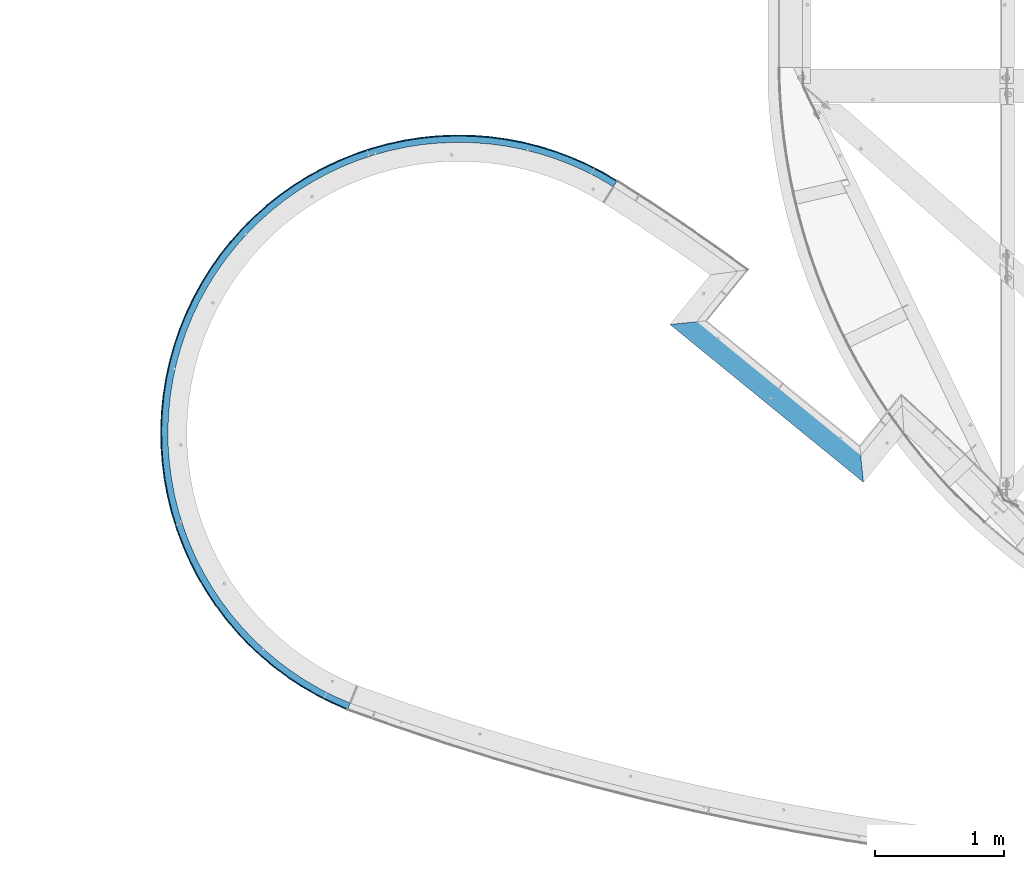
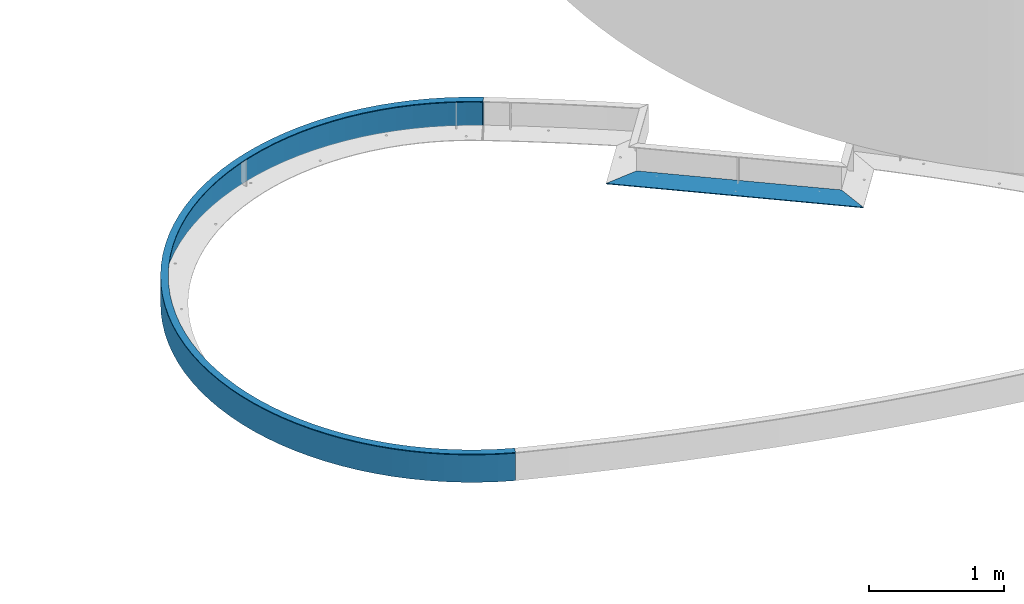
# One storey, part 1139 of 1763: 3 beams, 2 elements without a shape of their own.
"""IFC2X3 building model written with IfcOpenShell, lengths in millimetres."""

from ifc_helpers import new_model, si_unit, frame, origin_with_axes, place, context, subcontext, project, spatial, faceted_brep, material, type_object, element, aggregate, save


model = new_model("IFC2X3")

# Units and contexts
model_context = context("Model", 3, precision=1e-05, world=origin_with_axes())
body_context = subcontext(model_context, "Body", "Model", "MODEL_VIEW")
ifc_project = project(units=[si_unit("LENGTHUNIT", "METRE", prefix="MILLI"), si_unit("AREAUNIT", "SQUARE_METRE"), si_unit("VOLUMEUNIT", "CUBIC_METRE"), si_unit("MASSUNIT", "GRAM", prefix="KILO"), si_unit("TIMEUNIT", "SECOND"), si_unit("PLANEANGLEUNIT", "RADIAN"), si_unit("SOLIDANGLEUNIT", "STERADIAN"), si_unit("THERMODYNAMICTEMPERATUREUNIT", "DEGREE_CELSIUS"), si_unit("LUMINOUSINTENSITYUNIT", "LUMEN")], contexts=[model_context])

# Site, building, storey
site_placement = place(None, origin_with_axes())
site = spatial("IfcSite", under=ifc_project, at=site_placement, CompositionType="ELEMENT")
building_placement = place(site_placement, origin_with_axes())
building = spatial("IfcBuilding", under=site, at=building_placement, Name="Undefined", CompositionType="ELEMENT")
storey_placement = place(building_placement, origin_with_axes())
storey = spatial("IfcBuildingStorey", under=building, at=storey_placement, Name="Undefined", CompositionType="ELEMENT", Elevation=0.0)

# Assembly, beam
assembly_1_placement = place(storey_placement, origin_with_axes())
assembly_1 = element("IfcElementAssembly", 1, at=assembly_1_placement, inside=storey, Name="PLATE", AssemblyPlace="NOTDEFINED", PredefinedType="RIGID_FRAME")
ifc_material = material(Name="STEEL/A36")
beam_type_1 = type_object("IfcBeamType", PredefinedType="NOTDEFINED")
beam_1_placement = place(assembly_1_placement, frame((-50551.7806836382, 61435.7488480634, -250.825), z_axis=(0.632146851379196, 0.774848603464812, 0.0), x_axis=(0.774848603464803, -0.632146851379207, 0.0)))
beam_1 = element("IfcBeam", 2, at=beam_1_placement, type_object=beam_type_1, material=ifc_material, Name="PLATE", context=body_context, shape_type="Brep", body=[
    faceted_brep([(1733.19834197282, 3.17500000000001, 98.4249999978765), (1733.19834197282, -3.17500000000001, 98.4249999978765), (1930.03816630962, -3.17500000000001, -98.4250000016746), (1930.03816630962, 3.17500000000001, -98.4250000016746), (196.860502942538, -3.17500000000001, 98.4249999994627), (3.14685166813433e-10, -3.17500000000001, -98.4249999999156), (5.59484760742635e-08, 3.17500000000001, -98.4250000019238), (196.860502942538, 3.17500000000001, 98.4249999994627)], [[[0, 1, 2, 3]], [[2, 1, 4, 5]], [[3, 2, 5, 6]], [[0, 3, 6, 7]], [[1, 0, 7, 4]], [[6, 5, 4, 7]]]),
])
aggregate(assembly_1, [beam_1])

# Assembly, beams
assembly_2_placement = place(storey_placement, origin_with_axes())
assembly_2 = element("IfcElementAssembly", 3, at=assembly_2_placement, inside=storey, Name="PLATE", AssemblyPlace="NOTDEFINED", PredefinedType="RIGID_FRAME")
beam_type_2 = type_object("IfcBeamType", PredefinedType="NOTDEFINED")
beam_2_placement = place(assembly_2_placement, frame((-53103.23759363, 58381.757357184, -130.175), z_axis=(0.0, 0.0, 1.0), x_axis=(-0.350524826944054, 0.93655343985052, 0.0)))
beam_2 = element("IfcBeam", 4, at=beam_2_placement, type_object=beam_type_2, material=ifc_material, Name="PLATE", context=body_context, shape_type="Brep", body=[
    faceted_brep([(9.08736150742334, 3.46457929573444, 123.825), (2.34236171624798, 1.03151245606205, 123.825), (2.34236171624798, 1.03151245606205, -123.825), (9.10397851659218, 3.44847585066236, -123.825), (-9.89530235528946e-10, 3.17499999998108, -123.825), (-9.89530235528946e-10, 3.17499999998108, 123.825), (91.7775950844662, 97.8795264448527, 123.825), (91.7775950844662, 97.8795264448527, -123.825), (188.821100887682, 187.180323025095, 123.825), (188.821100887682, 187.180323025095, -123.825), (290.812861357786, 270.785078180852, 123.825), (290.812861357786, 270.785078180852, -123.825), (397.419023139155, 348.420125412711, 123.825), (397.419023139155, 348.420125412711, -123.825), (508.290628387724, 419.831339084303, 123.825), (508.290628387724, 419.831339084303, -123.825), (623.064757027547, 484.784966261039, 123.825), (623.064757027547, 484.784966261039, -123.825), (741.365714710279, 543.068391862096, 123.825), (741.365714710279, 543.068391862096, -123.825), (862.806262589191, 594.490834621192, 123.825), (862.806262589191, 594.490834621192, -123.825), (986.988884882318, 638.883971577801, 123.825), (986.988884882318, 638.883971577801, -123.825), (1113.50709007529, 676.102489054894, 123.825), (1113.50709007529, 676.102489054894, -123.825), (1241.94674150496, 706.024558319503, 123.825), (1241.94674150496, 706.024558319503, -123.825), (1371.88741296792, 728.552234369148, 123.825), (1371.88741296792, 728.552234369148, -123.825), (1502.90376491715, 743.611776538808, 123.825), (1502.90376491715, 743.611776538808, -123.825), (1634.56693674136, 751.153889878933, 123.825), (1634.56693674136, 751.153889878933, -123.825), (1766.44595057011, 751.153886514374, 123.825), (1766.44595057011, 751.153886514374, -123.825), (1898.10912200947, 743.611766456161, 123.825), (1898.10912200947, 743.611766456161, -123.825), (2029.1254731903, 728.552217601402, 123.825), (2029.1254731903, 728.552217601395, -123.825), (2159.06614350379, 706.024534921544, 123.825), (2159.06614350379, 706.024534921544, -123.825), (2287.50579340667, 676.10245910332, 123.825), (2287.50579340667, 676.10245910332, -123.825), (2414.02399670058, 638.883935170645, 123.825), (2414.02399670058, 638.883935170645, -123.825), (2538.20661672855, 594.490791877633, 123.825), (2538.20661672855, 594.490791877633, -123.825), (2659.64716198364, 543.068342922052, 123.825), (2659.64716198364, 543.068342922052, -123.825), (2777.94811669247, 484.784911284696, 123.825), (2777.94811669247, 484.784911284696, -123.825), (2892.72224201803, 419.83127825163, 123.825), (2892.72224201803, 419.83127825163, -123.825), (3003.59384362286, 348.420058922824, 123.825), (3003.59384362286, 348.420058922824, -123.825), (3110.20000144291, 270.785006251401, 123.825), (3110.20000144291, 270.785006251401, -123.825), (3212.19175764707, 187.18024589153, 123.825), (3212.19175764707, 187.180245891526, -123.825), (3309.23525889374, 97.8794443596453, 123.825), (3309.23525889374, 97.8794443596453, -123.825), (3401.01284914491, 3.17491323186914, 123.825), (3401.01284914484, 3.1749132320474, -123.825), (3487.22410946216, -96.6233476819216, 123.825), (3487.22410946216, -96.6233476819216, -123.825), (3567.58684137736, -201.188665096819, 123.825), (3567.58684137736, -201.188665096819, -123.825), (3641.83799062415, -310.178761539035, 123.825), (3641.83799062415, -310.178761539035, -123.825), (3709.73450820304, -423.236875744129, 123.825), (3709.73450820304, -423.236875744129, -123.825), (3771.05414596258, -539.992930456479, 123.825), (3771.05414596258, -539.992930456479, -123.825), (3825.59618409225, -660.064743816703, 123.825), (3825.59618409225, -660.064743816703, -123.825), (3873.18208814609, -783.059280371515, 123.825), (3873.18208814609, -783.059280371515, -123.825), (3913.65609344582, -908.573937611007, 123.825), (3913.65609344582, -908.573937611007, -123.825), (3946.88571495132, -1036.19786382219, 123.825), (3946.88571495132, -1036.19786382219, -123.825), (3972.76218092848, -1165.51330294484, 123.825), (3972.76218092848, -1165.51330294484, -123.825), (3991.20078899585, -1296.09696202779, 123.825), (3991.20078899585, -1296.09696202779, -123.825), (4002.14118338407, -1427.52139680908, 123.825), (4002.14118338407, -1427.52139680908, -123.825), (4005.54755250046, -1559.35641088499, 123.825), (4005.54755250046, -1559.35641088499, -123.825), (4001.40874615256, -1691.17046388757, 123.825), (4001.40874615256, -1691.17046388757, -123.825), (3989.73831204641, -1822.53208406153, 123.825), (3989.73831204641, -1822.53208406153, -123.825), (3970.57445144029, -1953.01128061647, 123.825), (3970.57445144029, -1953.01128061647, -123.825), (3943.97989409928, -2082.18095123146, 123.825), (3943.97989409928, -2082.18095123147, -123.825), (3910.04169295948, -2209.61828010471, 123.825), (3910.04169295948, -2209.61828010471, -123.825), (3868.87093917457, -2334.90612197189, 123.825), (3868.87093917457, -2334.90612197189, -123.825), (3820.60239847701, -2457.63436756303, 123.825), (3820.60239847701, -2457.63436756303, -123.825), (3765.39407004451, -2577.40128602819, 123.825), (3765.39407004451, -2577.40128602819, -123.825), (3703.42666931542, -2693.81483993767, 123.825), (3703.42666931542, -2693.81483993767, -123.825), (3634.90303644647, -2806.49396855247, 123.825), (3634.90303644647, -2806.49396855247, -123.825), (3560.04747234848, -2915.06983516436, 123.825), (3560.04747234848, -2915.06983516436, -123.825), (3479.10500447416, -3019.18703442253, 123.825), (3479.10500447416, -3019.18703442253, -123.825), (3392.34058476069, -3118.5047556949, 123.825), (3392.34058476069, -3118.5047556949, -123.825), (3300.03822235292, -3212.69789865603, 123.825), (3300.03822235292, -3212.69789865603, -123.825), (3202.50005394581, -3301.45813744986, 123.825), (3202.50005394581, -3301.45813744986, -123.825), (3100.04535478941, -3384.49492994407, 123.825), (3100.04535478941, -3384.49492994407, -123.825), (3098.11761481265, -3381.97214422654, 123.825), (3098.11761481265, -3381.97214422654, -123.825), (3101.1230338271, -3375.45116675187, 123.825), (3101.12303386677, -3375.45116680082, -123.825), (3198.36233045175, -3296.64131855283, 123.825), (3198.36233045175, -3296.64131855283, -123.825), (3295.63179867767, -3208.12559831656, -123.825), (3295.63179867767, -3208.12559831656, 123.825), (3387.67988461185, -3114.19194059074, -123.825), (3387.67988461185, -3114.19194059074, 123.825), (3474.20528389179, -3015.14782184892, -123.825), (3474.20528389179, -3015.14782184892, 123.825), (3554.92476976696, -2911.31744682337, -123.825), (3554.92476976696, -2911.31744682337, 123.825), (3629.57412019532, -2803.04068727395, -123.825), (3629.57412019532, -2803.04068727395, 123.825), (3697.90898273091, -2690.6719694734, -123.825), (3697.90898273091, -2690.6719694734, 123.825), (3759.70567437168, -2574.57911405088, -123.825), (3759.70567437168, -2574.57911405088, 123.825), (3814.76191374926, -2455.14213199131, -123.825), (3814.76191374926, -2455.14213199131, 123.825), (3862.89748326391, -2332.75198073151, -123.825), (3862.89748326391, -2332.75198073151, 123.825), (3903.95481899737, -2207.80928442488, -123.825), (3903.95481899737, -2207.80928442488, 123.825), (3937.79952647265, -2080.72302256385, -123.825), (3937.79952647265, -2080.72302256385, 123.825), (3964.32082057228, -1951.90919125223, -123.825), (3964.32082057228, -1951.90919125223, 123.825), (3983.43188817539, -1821.78944151005, -123.825), (3983.43188817539, -1821.78944151005, 123.825), (3995.07017232622, -1690.78969906784, -123.825), (3995.07017232622, -1690.78969906784, 123.825), (3999.19757700403, -1559.3387701684, -123.825), (3999.19757700403, -1559.3387701684, 123.825), (3995.80059182434, -1427.86693793963, -123.825), (3995.80059182434, -1427.86693793963, 123.825), (3984.89033626283, -1296.80455393308, -123.825), (3984.89033626283, -1296.80455393308, 123.825), (3966.50252325762, -1166.58062943845, -123.825), (3966.50252325762, -1166.58062943845, 123.825), (3940.69734230878, -1037.62143118529, -123.825), (3940.69734230878, -1037.62143118529, 123.825), (3907.55926245787, -910.349086028553, -123.825), (3907.55926245787, -910.349086028553, 123.825), (3867.19675579229, -785.180199185335, -123.825), (3867.19675579229, -785.180199185335, 123.825), (3819.7419423797, -662.524490545766, -123.825), (3819.7419423797, -662.524490545766, 123.825), (3765.35015779453, -542.783453521941, -123.825), (3765.35015779453, -542.783453521941, 123.825), (3704.19944465236, -426.349040824913, -123.825), (3704.19944465236, -426.349040824913, 123.825), (3636.48996981655, -313.602381471475, -123.825), (3636.48996981655, -313.602381471475, 123.825), (3562.44336918477, -204.912533220708, -123.825), (3562.44336918477, -204.912533220708, 123.825), (3482.30202219999, -100.635274523687, -123.825), (3482.30202219999, -100.635274523687, 123.825), (3396.32825846103, -1.1119399408708, 123.825), (3396.32825846103, -1.1119399408708, -123.825), (3304.80349903015, 93.3316971688291, -123.825), (3304.80349903015, 93.3316971688291, 123.825), (3208.02733524526, 182.386490989647, -123.825), (3208.02733524526, 182.386490989647, 123.825), (3106.31654805882, 265.760935211507, -123.825), (3106.31654805882, 265.760935211507, 123.825), (3000.00407110638, 343.182117220204, -123.825), (3000.00407110638, 343.182117220204, 123.825), (2889.43790090266, 414.396611432217, -123.825), (2889.43790090266, 414.396611432217, 123.825), (2774.97995773198, 479.171308841942, -123.825), (2774.97995773198, 479.171308841942, 123.825), (2657.0049009612, 537.294180065903, -123.825), (2657.0049009612, 537.294180065903, 123.825), (2535.89890265366, 588.574969386325, -123.825), (2535.89890265366, 588.574969386325, 123.825), (2412.05838349805, 632.845817522055, -123.825), (2412.05838349805, 632.845817522055, 123.825), (2285.88871519001, 669.961811088542, -123.825), (2285.88871519001, 669.961811088542, 123.825), (2157.80289351421, 699.801456948069, -123.825), (2157.80289351421, 699.801456948069, 123.825), (2028.22018647012, 722.267079897701, -123.825), (2028.22018647012, 722.267079897701, 123.825), (1897.5647618668, 737.285142393102, -123.825), (1897.5647618668, 737.285142393102, 123.825), (1766.26429887889, 744.806485261637, -123.825), (1766.26429887889, 744.806485261637, 123.825), (1634.74858810871, 744.806488616923, -123.825), (1634.74858810871, 744.806488616923, 123.825), (1503.448124737, 737.285152447977, -123.825), (1503.448124737, 737.285152447977, 123.825), (1372.79269936739, 722.26709661926, -123.825), (1372.79269936739, 722.26709661926, 123.825), (1243.20999117701, 699.801480281571, -123.825), (1243.20999117701, 699.801480281571, 123.825), (1115.12416797863, 669.961840957611, -123.825), (1115.12416797863, 669.961840957611, 123.825), (988.954497776765, 632.845853828916, -123.825), (988.954497776765, 632.845853828916, 123.825), (865.113976362234, 588.57501201213, -123.825), (865.113976362234, 588.57501201213, 123.825), (744.0079754381, 537.294228871131, -123.825), (744.0079754381, 537.294228871131, 123.825), (626.032915701609, 479.171363666821, -123.825), (626.032915701609, 479.171363666821, 123.825), (511.574969225781, 414.396672097308, -123.825), (511.574969225781, 414.396672097308, 123.825), (401.008795388378, 343.182183526922, -123.825), (401.008795388378, 343.182183526922, 123.825), (294.696314485525, 265.761006942812, -123.825), (294.696314485525, 265.761006942812, 123.825), (192.985523044917, 182.386567910729, -123.825), (192.985523044917, 182.386567910729, 123.825), (96.2093547160184, 93.3317790278998, -123.825), (96.2093547160184, 93.3317790278998, 123.825)], [[[0, 1, 2, 3]], [[4, 5, 6, 7]], [[6, 8, 9, 7]], [[8, 10, 11, 9]], [[10, 12, 13, 11]], [[12, 14, 15, 13]], [[14, 16, 17, 15]], [[16, 18, 19, 17]], [[18, 20, 21, 19]], [[20, 22, 23, 21]], [[22, 24, 25, 23]], [[24, 26, 27, 25]], [[26, 28, 29, 27]], [[28, 30, 31, 29]], [[30, 32, 33, 31]], [[32, 34, 35, 33]], [[34, 36, 37, 35]], [[36, 38, 39, 37]], [[38, 40, 41, 39]], [[40, 42, 43, 41]], [[42, 44, 45, 43]], [[44, 46, 47, 45]], [[46, 48, 49, 47]], [[48, 50, 51, 49]], [[50, 52, 53, 51]], [[52, 54, 55, 53]], [[54, 56, 57, 55]], [[56, 58, 59, 57]], [[58, 60, 61, 59]], [[60, 62, 63, 61]], [[63, 62, 64, 65]], [[64, 66, 67, 65]], [[66, 68, 69, 67]], [[68, 70, 71, 69]], [[70, 72, 73, 71]], [[72, 74, 75, 73]], [[74, 76, 77, 75]], [[76, 78, 79, 77]], [[78, 80, 81, 79]], [[80, 82, 83, 81]], [[82, 84, 85, 83]], [[84, 86, 87, 85]], [[86, 88, 89, 87]], [[88, 90, 91, 89]], [[90, 92, 93, 91]], [[92, 94, 95, 93]], [[94, 96, 97, 95]], [[96, 98, 99, 97]], [[98, 100, 101, 99]], [[100, 102, 103, 101]], [[102, 104, 105, 103]], [[104, 106, 107, 105]], [[106, 108, 109, 107]], [[108, 110, 111, 109]], [[110, 112, 113, 111]], [[112, 114, 115, 113]], [[114, 116, 117, 115]], [[116, 118, 119, 117]], [[118, 120, 121, 119]], [[121, 120, 122, 123]], [[124, 125, 123, 122]], [[126, 127, 125, 124]], [[128, 127, 126, 129]], [[130, 128, 129, 131]], [[132, 130, 131, 133]], [[134, 132, 133, 135]], [[136, 134, 135, 137]], [[138, 136, 137, 139]], [[140, 138, 139, 141]], [[142, 140, 141, 143]], [[144, 142, 143, 145]], [[146, 144, 145, 147]], [[148, 146, 147, 149]], [[150, 148, 149, 151]], [[152, 150, 151, 153]], [[154, 152, 153, 155]], [[156, 154, 155, 157]], [[158, 156, 157, 159]], [[160, 158, 159, 161]], [[162, 160, 161, 163]], [[164, 162, 163, 165]], [[166, 164, 165, 167]], [[168, 166, 167, 169]], [[170, 168, 169, 171]], [[172, 170, 171, 173]], [[174, 172, 173, 175]], [[176, 174, 175, 177]], [[178, 176, 177, 179]], [[180, 178, 179, 181]], [[182, 183, 180, 181]], [[184, 183, 182, 185]], [[186, 184, 185, 187]], [[188, 186, 187, 189]], [[190, 188, 189, 191]], [[192, 190, 191, 193]], [[194, 192, 193, 195]], [[196, 194, 195, 197]], [[198, 196, 197, 199]], [[200, 198, 199, 201]], [[202, 200, 201, 203]], [[204, 202, 203, 205]], [[206, 204, 205, 207]], [[208, 206, 207, 209]], [[210, 208, 209, 211]], [[212, 210, 211, 213]], [[214, 212, 213, 215]], [[216, 214, 215, 217]], [[218, 216, 217, 219]], [[220, 218, 219, 221]], [[222, 220, 221, 223]], [[224, 222, 223, 225]], [[226, 224, 225, 227]], [[228, 226, 227, 229]], [[230, 228, 229, 231]], [[232, 230, 231, 233]], [[234, 232, 233, 235]], [[236, 234, 235, 237]], [[238, 236, 237, 239]], [[238, 239, 0, 3]], [[4, 7, 9, 11, 13, 15, 17, 19, 21, 23, 25, 27, 29, 31, 33, 35, 37, 39, 41, 43, 45, 47, 49, 51, 53, 55, 57, 59, 61, 63, 65, 67, 69, 71, 73, 75, 77, 79, 81, 83, 85, 87, 89, 91, 93, 95, 97, 99, 101, 103, 105, 107, 109, 111, 113, 115, 117, 119, 121, 123, 125, 127, 128, 130, 132, 134, 136, 138, 140, 142, 144, 146, 148, 150, 152, 154, 156, 158, 160, 162, 164, 166, 168, 170, 172, 174, 176, 178, 180, 183, 184, 186, 188, 190, 192, 194, 196, 198, 200, 202, 204, 206, 208, 210, 212, 214, 216, 218, 220, 222, 224, 226, 228, 230, 232, 234, 236, 238, 3, 2]], [[5, 4, 2, 1]], [[239, 237, 235, 233, 231, 229, 227, 225, 223, 221, 219, 217, 215, 213, 211, 209, 207, 205, 203, 201, 199, 197, 195, 193, 191, 189, 187, 185, 182, 181, 179, 177, 175, 173, 171, 169, 167, 165, 163, 161, 159, 157, 155, 153, 151, 149, 147, 145, 143, 141, 139, 137, 135, 133, 131, 129, 126, 124, 122, 120, 118, 116, 114, 112, 110, 108, 106, 104, 102, 100, 98, 96, 94, 92, 90, 88, 86, 84, 82, 80, 78, 76, 74, 72, 70, 68, 66, 64, 62, 60, 58, 56, 54, 52, 50, 48, 46, 44, 42, 40, 38, 36, 34, 32, 30, 28, 26, 24, 22, 20, 18, 16, 14, 12, 10, 8, 6, 5, 1, 0]]]),
])
beam_type_3 = type_object("IfcBeamType", PredefinedType="NOTDEFINED")
beam_3_placement = place(assembly_2_placement, frame((-53079.4488698737, 58390.6606092681, -3.17499999999491), z_axis=(-0.93655458541008, -0.350521766153478, 0.0), x_axis=(-0.350521766153479, 0.936554585410079, 0.0)))
beam_3 = element("IfcBeam", 5, at=beam_3_placement, type_object=beam_type_3, material=ifc_material, Name="PLATE", context=body_context, shape_type="Brep", body=[
    faceted_brep([(46.5814180893212, 3.1750000067129, -5.4456119460483), (42.1613151708298, 1.32569439870167e-07, -10.006679626189), (-8.84756445884705e-09, 9.69761293490023e-09, 28.5749999999134), (4.42000042708241, 3.175, 33.1359619234681), (226.300451900956, 3.175, 169.43614007338), (325.763236474842, 3.175, 250.967892813333), (325.763236474842, -3.175, 250.967892813333), (226.300451900956, -3.175, 169.43614007338), (429.725998550493, 3.175, 326.677973526785), (429.725998550493, -3.175, 326.677973526785), (537.848434369764, 3.175, 396.318558623025), (537.848434369764, -3.175, 396.318558623025), (649.776624216407, 3.175, 459.661691934307), (649.776624216407, -3.175, 459.661691934307), (765.144190909894, 3.175, 516.500030890176), (765.144190909894, -3.175, 516.500030890176), (883.573499076403, 3.175, 566.647525216784), (883.573499076403, -3.175, 566.647525216784), (1004.67689127168, 3.175, 609.940025939606), (1004.67689127168, -3.175, 609.940025939606), (1128.05795690918, 3.175, 646.235822696173), (1128.05795690918, -3.175, 646.235822696173), (1253.31282984023, 3.175, 675.416107599951), (1253.31282984023, -3.175, 675.416107599951), (1380.03151033861, 3.175, 697.385364136942), (1380.03151033861, -3.175, 697.385364136942), (1507.7992071623, 3.175, 712.071679822187), (1507.7992071623, -3.175, 712.071679822187), (1636.19769529944, 3.175, 719.426981592591), (1636.19769529944, -3.175, 719.426981592591), (1764.80668495411, 3.175, 719.4271931656), (1764.80668495411, -3.175, 719.4271931656), (1893.20519729078, 3.175, 712.072313848668), (1893.20519729078, -3.175, 712.072313848668), (2020.97294243431, 3.175, 697.386418541515), (2020.97294243431, -3.175, 697.386418541515), (2147.6916952147, 3.175, 675.417578931218), (2147.6916952147, -3.175, 675.417578931218), (2272.94666415329, 3.175, 646.237706137992), (2272.94666415329, -3.175, 646.237706137992), (2396.32784920964, 3.175, 609.942315326851), (2396.32784920964, -3.175, 609.942315326851), (2517.43138384413, 3.175, 566.650213055556), (2517.43138384413, -3.175, 566.650213055556), (2635.86085700402, 3.175, 516.503108382305), (2635.86085700402, -3.175, 516.503108382305), (2751.22861070493, 3.175, 459.665149006178), (2751.22861070493, -3.175, 459.665149006178), (2863.15700896093, 3.175, 396.322383958515), (2863.15700896093, -3.175, 396.322383958515), (2971.27967390929, 3.175, 326.682154604328), (2971.27967390929, -3.175, 326.682154604328), (3075.24268508377, 3.175, 250.972415946919), (3075.24268508377, -3.175, 250.972415946919), (3174.70573791079, 3.175, 169.440990457315), (3174.70573791079, -3.175, 169.440990457315), (3269.34325763649, 3.175, 82.3547568712456), (3269.34325763649, -3.175, 82.3547568712456), (3358.84546503727, 3.175, -10.0012233906164), (3358.8454650381, -3.175, -10.0012233913767), (91.7773763294535, -3.175, 123.279316319877), (188.82064159213, -3.175, 212.579926638777), (188.82064159213, 3.175, 212.579926638777), (91.7773763294535, 3.175, 123.279316319877), (290.812141778399, -3.175, 296.184521165163), (290.812141778399, 3.175, 296.184521165163), (397.418025708073, -3.175, 373.819435010297), (397.418025708073, 3.175, 373.819435010297), (508.289337829949, -3.175, 445.230543981812), (508.289337829949, 3.175, 445.230543981812), (623.063160466249, -3.175, 510.184096414461), (623.063160466249, 3.175, 510.184096414461), (741.363801759566, -3.175, 568.467478314953), (741.363801759566, 3.175, 568.467478314953), (862.804025433914, -3.175, 619.889909316309), (862.804025433914, 3.175, 619.889909316309), (986.986318344381, -3.175, 664.283067163771), (986.986318344381, 3.175, 664.283067163771), (1113.50419166616, -3.175, 701.501638687969), (1113.50419166616, 3.175, 701.501638687969), (1241.94351146411, -3.175, 731.423795461978), (1241.94351146411, 3.175, 731.423795461978), (1371.88385428707, -3.175, 753.951592585137), (1371.88385428707, 3.175, 753.951592585137), (1502.89988334982, -3.175, 769.011289288428), (1502.89988334982, 3.175, 769.011289288428), (1634.56274079808, -3.175, 776.553590311883), (1634.56274079808, 3.175, 776.553590311883), (1766.44145149895, -3.175, 776.553807263859), (1766.44145149895, 3.175, 776.553807263859), (1898.10433376198, -3.175, 769.011939434229), (1898.10433376198, 3.175, 769.011939434229), (2029.12041237306, -3.175, 753.952673796619), (2029.12041237306, 3.175, 753.952673796619), (2159.06082931568, -3.175, 731.425304199987), (2159.06082931568, 3.175, 731.425304199987), (2287.50024756206, -3.175, 701.50357001392), (2287.50024756206, 3.175, 701.50357001392), (2414.01824333875, -3.175, 664.285414755799), (2414.01824333875, 3.175, 664.285414755799), (2538.20068230978, -3.175, 619.892665489991), (2538.20068230978, 3.175, 619.892665489991), (2659.64107517226, -3.175, 568.470634048434), (2659.64107517226, 3.175, 568.470634048434), (2777.94190822743, -3.175, 510.187641378016), (2777.94190822743, 3.175, 510.187641378016), (2892.71594457162, -3.175, 445.234466571615), (2892.71594457162, 3.175, 445.234466571615), (3003.58749164791, -3.175, 373.823722386456), (3003.58749164791, 3.175, 373.823722386456), (3110.19363100943, -3.175, 296.189159293706), (3110.19363100943, 3.175, 296.189159293706), (3212.18540626885, -3.175, 212.584900337592), (3212.18540626885, 3.175, 212.584900337592), (3309.22896534558, -3.175, 123.284609308459), (3309.22896534558, 3.175, 123.284609308459), (3401.00665327163, -3.175, 28.5805949525784), (3401.00665327163, 3.175, 28.5805949525784), (3487.21805197907, -3.175, -71.2171458575503), (3487.21805197907, 3.175, -71.2171458575503), (3567.58096366446, -3.175, -175.781942816262), (3567.58096366446, 3.175, -175.781942816262), (3641.83233451658, -3.175, -284.771521511415), (3641.83233451658, 3.175, -284.771521511415), (3709.7291157741, -3.175, -397.829123787593), (3709.7291157741, 3.175, -397.829123787593), (3771.04905930345, -3.175, -514.584675531933), (3771.04905930345, 3.175, -514.584675531933), (3825.59144508894, -3.175, -634.655998046488), (3825.59144508895, 3.175, -634.655998046492), (3873.17773825435, -3.175, -757.650059042728), (3873.17773825435, 3.175, -757.650059042728), (3913.65217346523, -3.175, -883.164259163386), (3913.65217346523, 3.175, -883.164259163386), (3946.88226479937, -3.175, -1010.78774982046), (3946.88226479937, 3.175, -1010.78774982046), (3972.75923941596, -3.175, -1140.10277803553), (3972.75923941596, 3.175, -1140.10277803553), (3991.19839360441, -3.175, -1270.68605388041), (3991.19839360441, 3.175, -1270.68605388041), (4002.13937004698, -3.175, -1402.11013604215), (4002.13937004698, 3.175, -1402.11013604215), (4005.54635538768, -3.175, -1533.9448309766), (4005.54635538768, 3.175, -1533.9448309766), (4001.40819746118, -3.175, -1665.75860107118), (4001.40819746118, 3.175, -1665.75860107118), (3989.73844179728, -3.175, -1797.11997720708), (3989.73844179728, 3.175, -1797.11997720708), (3970.57528728212, -3.175, -1927.59897109728), (3970.5752872821, 3.175, -1927.59897109728), (3943.98146112078, -3.175, -2056.76848277737), (3943.98146112078, 3.175, -2056.76848277737), (3910.04401351094, -3.175, -2184.2056986419), (3910.04401351094, 3.175, -2184.2056986419), (3868.8740326993, -3.175, -2309.49347545009), (3868.87403269931, 3.175, -2309.49347545009), (3820.60628135393, -3.175, -2432.22170577072), (3820.60628135393, 3.175, -2432.22170577072), (3765.39875544235, -3.175, -2551.98866039634), (3765.39875544235, 3.175, -2551.98866039634), (3703.43216705964, -3.175, -2668.40230333299), (3703.43216705964, 3.175, -2668.40230333299), (3634.90935289935, -3.175, -2781.08157506086), (3634.90935289935, 3.175, -2781.08157506086), (3560.05461030325, -3.175, -2889.65763986543), (3560.05461030325, 3.175, -2889.65763986543), (3479.11296306366, -3.175, -2993.775093156), (3479.11296306366, 3.175, -2993.775093156), (3392.34935938123, -3.175, -3093.09312481999), (3392.34935938123, 3.175, -3093.09312481999), (3300.04780460382, -3.175, -3187.28663480472), (3300.04780460382, 3.175, -3187.28663480472), (3202.51043158503, -3.175, -3276.04729727503), (3202.51043158503, 3.175, -3276.04729727503), (3100.05651170571, -3.175, -3359.08456986345), (3100.05651170571, 3.07063627857929e-08, -3359.08456986345), (3104.98879128847, 3.17499996740373, -3355.08703570685), (3065.35689938731, -3.175, -3313.67466560306), (3065.35689938731, 8.0351691522651e-08, -3313.67466560306), (3070.29690812776, 3.175, -3309.67086708707), (3165.27063869996, -3.175, -3232.69616896373), (3165.27063869996, 3.175, -3232.69616896373), (3260.38972904338, 3.175, -3146.13618471206), (3260.38972904338, -3.175, -3146.13618471206), (3350.4028148584, 3.175, -3054.27805168363), (3350.4028148584, -3.175, -3054.27805168363), (3435.01525419077, 3.175, -2957.42245126921), (3435.01525419077, -3.175, -2957.42245126921), (3513.95008314958, 3.175, -2855.88642318728), (3513.95008314958, -3.175, -2855.88642318728), (3586.94892249972, 3.175, -2750.00232771046), (3586.94892249972, -3.175, -2750.00232771046), (3653.77282342069, 3.175, -2640.11675774282), (3653.77282342069, -3.175, -2640.11675774282), (3714.20304966344, 3.175, -2526.58940430911), (3714.20304966344, -3.175, -2526.58940430911), (3768.04179354482, 3.175, -2409.79187916973), (3768.04179354482, -3.175, -2409.79187916973), (3815.11282343621, 3.175, -2290.10649841512), (3815.11282343621, -3.175, -2290.10649841512), (3855.2620606266, 3.175, -2167.92503102158), (3855.2620606266, -3.175, -2167.92503102158), (3888.35808367208, 3.175, -2043.64741646456), (3888.35808367208, -3.175, -2043.64741646456), (3914.2925585808, 3.175, -1917.68045558743), (3914.2925585808, -3.175, -1917.68045558743), (3932.98059342506, 3.175, -1790.43647901066), (3932.98059342506, -3.175, -1790.43647901066), (3944.36101622019, 3.175, -1662.33199744029), (3944.36101622019, -3.175, -1662.33199744029), (3948.39657516015, 3.175, -1533.78633829362), (3948.39657516015, -3.175, -1533.78633829362), (3945.07406055481, 3.175, -1405.22027310491), (3945.07406055481, -3.175, -1405.22027310491), (3934.40434806948, 3.175, -1277.054640204), (3934.40434806948, -3.175, -1277.054640204), (3916.4223631254, 3.175, -1149.70896717629), (3916.4223631254, -3.175, -1149.70896717629), (3891.1869665775, 3.175, -1023.60009761321), (3891.1869665775, -3.175, -1023.60009761321), (3858.78076204374, 3.175, -899.140826648269), (3858.78076204374, -3.175, -899.140826648269), (3819.30982551686, 3.175, -776.738549745023), (3819.30982551686, -3.175, -776.738549745023), (3772.9033581432, 3.175, -656.79392915991), (3772.9033581432, -3.175, -656.79392915991), (3719.71326330562, 3.175, -539.699582445061), (3719.71326330562, -3.175, -539.699582445061), (3659.91364939456, 3.175, -425.838797283992), (3659.91364939456, -3.175, -425.838797283992), (3593.70025989496, 3.175, -315.584276867008), (3593.70025989496, -3.175, -315.584276867008), (3521.28983265445, 3.175, -209.296919913075), (3521.28983265445, -3.175, -209.296919913075), (3442.91939043031, 3.175, -107.324639331535), (3442.91939043031, -3.175, -107.324639331535), (-8.84756445884705e-09, -3.175, 28.5749999999134), (42.1613151708298, -3.175, -10.006679626189), (131.663218704693, -3.175, 82.3495951138248), (131.663218704693, 3.175, 82.3495951138248)], [[[0, 1, 2, 3]], [[4, 5, 6, 7]], [[5, 8, 9, 6]], [[8, 10, 11, 9]], [[10, 12, 13, 11]], [[12, 14, 15, 13]], [[14, 16, 17, 15]], [[16, 18, 19, 17]], [[18, 20, 21, 19]], [[20, 22, 23, 21]], [[22, 24, 25, 23]], [[24, 26, 27, 25]], [[26, 28, 29, 27]], [[28, 30, 31, 29]], [[30, 32, 33, 31]], [[32, 34, 35, 33]], [[34, 36, 37, 35]], [[36, 38, 39, 37]], [[38, 40, 41, 39]], [[40, 42, 43, 41]], [[42, 44, 45, 43]], [[44, 46, 47, 45]], [[46, 48, 49, 47]], [[48, 50, 51, 49]], [[50, 52, 53, 51]], [[52, 54, 55, 53]], [[54, 56, 57, 55]], [[56, 58, 59, 57]], [[60, 61, 62, 63]], [[61, 64, 65, 62]], [[64, 66, 67, 65]], [[66, 68, 69, 67]], [[68, 70, 71, 69]], [[70, 72, 73, 71]], [[72, 74, 75, 73]], [[74, 76, 77, 75]], [[76, 78, 79, 77]], [[78, 80, 81, 79]], [[80, 82, 83, 81]], [[82, 84, 85, 83]], [[84, 86, 87, 85]], [[86, 88, 89, 87]], [[88, 90, 91, 89]], [[90, 92, 93, 91]], [[92, 94, 95, 93]], [[94, 96, 97, 95]], [[96, 98, 99, 97]], [[98, 100, 101, 99]], [[100, 102, 103, 101]], [[102, 104, 105, 103]], [[104, 106, 107, 105]], [[106, 108, 109, 107]], [[108, 110, 111, 109]], [[110, 112, 113, 111]], [[112, 114, 115, 113]], [[114, 116, 117, 115]], [[117, 116, 118, 119]], [[118, 120, 121, 119]], [[120, 122, 123, 121]], [[122, 124, 125, 123]], [[124, 126, 127, 125]], [[126, 128, 129, 127]], [[128, 130, 131, 129]], [[130, 132, 133, 131]], [[132, 134, 135, 133]], [[134, 136, 137, 135]], [[136, 138, 139, 137]], [[138, 140, 141, 139]], [[140, 142, 143, 141]], [[142, 144, 145, 143]], [[144, 146, 147, 145]], [[146, 148, 149, 147]], [[148, 150, 151, 149]], [[150, 152, 153, 151]], [[152, 154, 155, 153]], [[154, 156, 157, 155]], [[156, 158, 159, 157]], [[158, 160, 161, 159]], [[160, 162, 163, 161]], [[162, 164, 165, 163]], [[164, 166, 167, 165]], [[166, 168, 169, 167]], [[168, 170, 171, 169]], [[170, 172, 173, 171]], [[173, 172, 174, 175, 176]], [[174, 177, 178, 175]], [[176, 175, 178, 179]], [[177, 180, 181, 179, 178]], [[182, 181, 180, 183]], [[184, 182, 183, 185]], [[186, 184, 185, 187]], [[188, 186, 187, 189]], [[190, 188, 189, 191]], [[192, 190, 191, 193]], [[194, 192, 193, 195]], [[196, 194, 195, 197]], [[198, 196, 197, 199]], [[200, 198, 199, 201]], [[202, 200, 201, 203]], [[204, 202, 203, 205]], [[206, 204, 205, 207]], [[208, 206, 207, 209]], [[210, 208, 209, 211]], [[212, 210, 211, 213]], [[214, 212, 213, 215]], [[216, 214, 215, 217]], [[218, 216, 217, 219]], [[220, 218, 219, 221]], [[222, 220, 221, 223]], [[224, 222, 223, 225]], [[226, 224, 225, 227]], [[228, 226, 227, 229]], [[230, 228, 229, 231]], [[232, 230, 231, 233]], [[234, 232, 233, 235]], [[59, 58, 234, 235]], [[233, 231, 229, 227, 225, 223, 221, 219, 217, 215, 213, 211, 209, 207, 205, 203, 201, 199, 197, 195, 193, 191, 189, 187, 185, 183, 180, 177, 174, 172, 170, 168, 166, 164, 162, 160, 158, 156, 154, 152, 150, 148, 146, 144, 142, 140, 138, 136, 134, 132, 130, 128, 126, 124, 122, 120, 118, 116, 114, 112, 110, 108, 106, 104, 102, 100, 98, 96, 94, 92, 90, 88, 86, 84, 82, 80, 78, 76, 74, 72, 70, 68, 66, 64, 61, 60, 236, 237, 238, 7, 6, 9, 11, 13, 15, 17, 19, 21, 23, 25, 27, 29, 31, 33, 35, 37, 39, 41, 43, 45, 47, 49, 51, 53, 55, 57, 59, 235]], [[239, 4, 7, 238]], [[63, 62, 65, 67, 69, 71, 73, 75, 77, 79, 81, 83, 85, 87, 89, 91, 93, 95, 97, 99, 101, 103, 105, 107, 109, 111, 113, 115, 117, 119, 121, 123, 125, 127, 129, 131, 133, 135, 137, 139, 141, 143, 145, 147, 149, 151, 153, 155, 157, 159, 161, 163, 165, 167, 169, 171, 173, 176, 179, 181, 182, 184, 186, 188, 190, 192, 194, 196, 198, 200, 202, 204, 206, 208, 210, 212, 214, 216, 218, 220, 222, 224, 226, 228, 230, 232, 234, 58, 56, 54, 52, 50, 48, 46, 44, 42, 40, 38, 36, 34, 32, 30, 28, 26, 24, 22, 20, 18, 16, 14, 12, 10, 8, 5, 4, 239, 0, 3]], [[236, 60, 63, 3, 2]], [[237, 236, 2, 1]], [[239, 238, 237, 1, 0]]]),
])
aggregate(assembly_2, [beam_3, beam_2])

save(model, "model.ifc")
